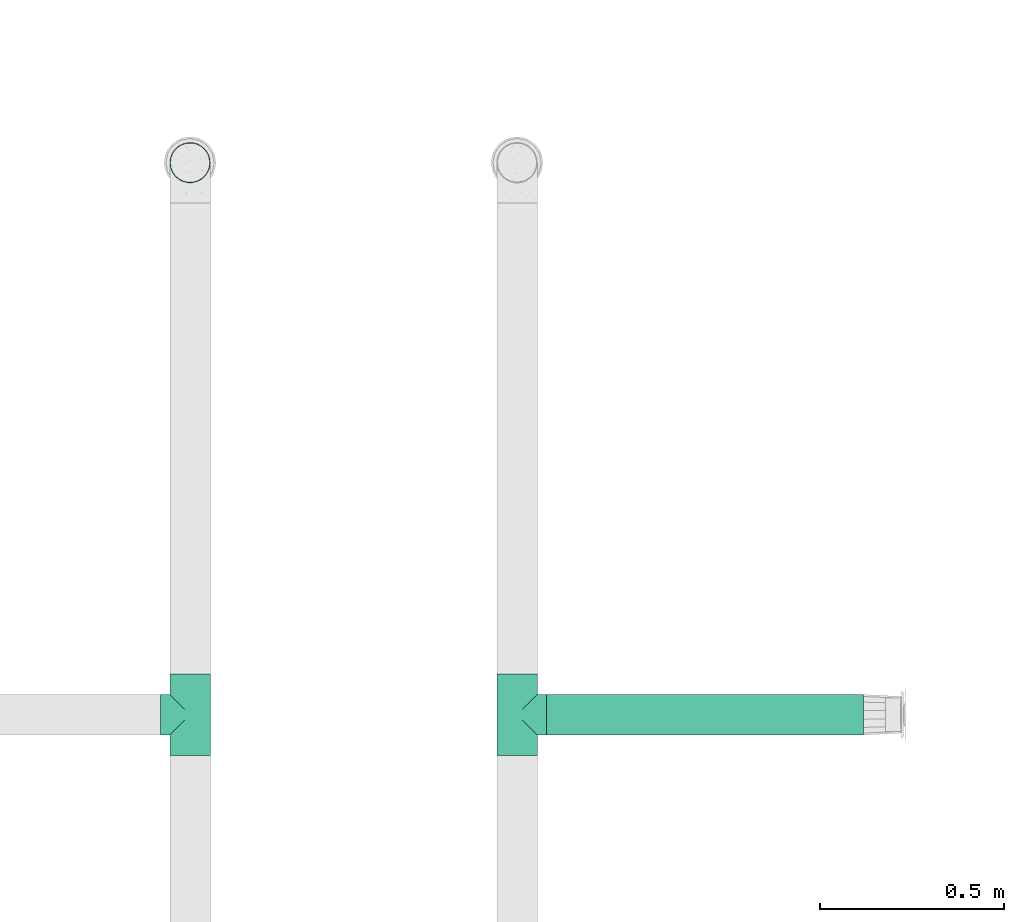
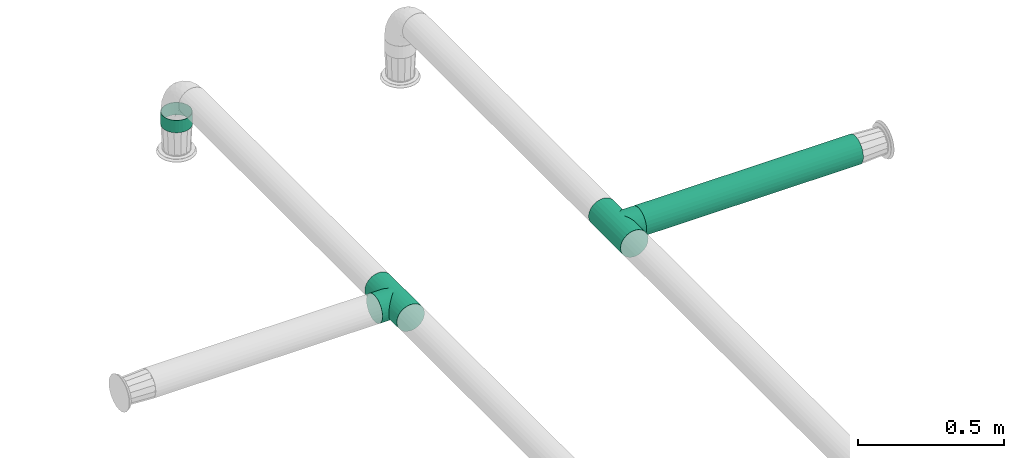
# One storey, part 28 of 123: 2 flow fittings, 2 flow segments.
"""IFC2X3 building model written with IfcOpenShell, lengths in millimetres."""

from ifc_helpers import new_model, entity, si_unit, converted_unit, derived_unit, direction, frame, origin_with_axes, origin_2d_with_axis, place, context, subcontext, project, spatial, hollow_circle, extrude, open_shell, surface_model, source, transform, mapped, material, layer, layer_set, layer_usage, type_object, element, save


model = new_model("IFC2X3")

# Units and contexts
model_context = context("Model", 3, precision=1e-05, world=origin_with_axes(), true_north=direction((0.0, 1.0)))
body_context = subcontext(model_context, "Body", "Model", "MODEL_VIEW")
ifc_project = project(units=[si_unit("AREAUNIT", "SQUARE_METRE"), si_unit("VOLUMEUNIT", "CUBIC_METRE", prefix="DECI"), si_unit("TIMEUNIT", "SECOND"), si_unit("THERMODYNAMICTEMPERATUREUNIT", "DEGREE_CELSIUS"), si_unit("PRESSUREUNIT", "PASCAL"), si_unit("MASSUNIT", "GRAM", prefix="KILO"), si_unit("LENGTHUNIT", "METRE", prefix="MILLI"), si_unit("POWERUNIT", "WATT"), si_unit("ELECTRICCURRENTUNIT", "AMPERE"), si_unit("ELECTRICVOLTAGEUNIT", "VOLT"), derived_unit("VOLUMETRICFLOWRATEUNIT", [(si_unit("VOLUMEUNIT", "CUBIC_METRE", prefix="DECI"), 1), (si_unit("TIMEUNIT", "SECOND"), -1)]), derived_unit("LINEARVELOCITYUNIT", [(si_unit("LENGTHUNIT", "METRE"), 1), (si_unit("TIMEUNIT", "SECOND"), -1)]), derived_unit("MASSDENSITYUNIT", [(si_unit("MASSUNIT", "GRAM", prefix="KILO"), 1), (si_unit("VOLUMEUNIT", "CUBIC_METRE"), -1)]), converted_unit("PLANEANGLEUNIT", "DEGREE", entity("IfcRatioMeasure", 0.01745), si_unit("PLANEANGLEUNIT", "RADIAN"), dimensions=[0, 0, 0, 0, 0, 0, 0])], contexts=[model_context])

# Site, building, storey
site_placement = place(None, origin_with_axes())
site = spatial("IfcSite", under=ifc_project, at=site_placement, CompositionType="ELEMENT")
building_placement = place(site_placement, origin_with_axes())
building = spatial("IfcBuilding", under=site, at=building_placement, Name="mc-building", CompositionType="ELEMENT")
storey_placement = place(building_placement, origin_with_axes())
storey = spatial("IfcBuildingStorey", under=building, at=storey_placement, Name="1. Korrus", CompositionType="ELEMENT", Elevation=0.0)

# Flow fitting
duct_fitting_type = type_object("IfcDuctFittingType", PredefinedType="JUNCTION")
shared_shape_1 = source(origin_with_axes(), body_context, "Body", "SurfaceModel", [
    surface_model("IfcShellBasedSurfaceModel", [(0.0, -80.0, -55.0), (14.23505, -80.0, -53.12592), (-14.23505, -80.0, -53.12592), (-53.12592, -80.0, 14.23505), (-27.5, -80.0, -47.63139), (-47.63139, -80.0, -27.5), (-38.89087, -80.0, -38.89087), (55.0, -80.0, 0.0), (53.12592, -80.0, 14.23505), (38.89087, -80.0, -38.89087), (27.5, -80.0, -47.63139), (53.12592, -80.0, -14.23505), (47.63139, -80.0, -27.5), (-53.12592, -80.0, -14.23505), (-47.63139, -80.0, 27.5), (-38.89087, -80.0, 38.89087), (14.23505, -80.0, 53.12592), (-27.5, -80.0, 47.63139), (-14.23505, -80.0, 53.12592), (47.63139, -80.0, 27.5), (38.89087, -80.0, 38.89087), (27.5, -80.0, 47.63139), (0.0, -80.0, 55.0), (-55.0, -80.0, 0.0), (0.0, 0.0, 55.0), (-7.4066, -7.4066, 54.49901), (-14.74521, -14.74521, 52.98659), (-21.93978, -21.93978, 50.43457), (-28.89905, -28.89905, 46.79578), (-35.50357, -35.50357, 42.00591), (-41.58668, -41.58668, 35.99373), (-46.92319, -46.92319, 28.69171), (-51.19777, -51.19777, 20.0945), (-50.37866, -80.0, 20.86752), (-54.01174, -54.01174, 10.37938), (-55.0, -55.0, 0.0), (-54.06296, -80.0, 7.11752), (-54.01174, -54.01174, -10.37938), (-51.19777, -51.19777, -20.0945), (-54.06296, -80.0, -7.11752), (-46.92319, -46.92319, -28.69171), (-41.58668, -41.58668, -35.99373), (-50.37866, -80.0, -20.86752), (-35.50357, -35.50357, -42.00591), (-21.93978, -21.93978, -50.43457), (-14.74521, -14.74521, -52.98659), (-7.4066, -7.4066, -54.49901), (0.0, 0.0, -55.0), (-28.89905, -28.89905, -46.79578), (7.4066, -7.4066, -54.49901), (14.74521, -14.74521, -52.98659), (21.93978, -21.93978, -50.43457), (28.89905, -28.89905, -46.79578), (35.50357, -35.50357, -42.00591), (41.58668, -41.58668, -35.99373), (46.92319, -46.92319, -28.69171), (51.19777, -51.19777, -20.0945), (50.37866, -80.0, -20.86752), (54.01174, -54.01174, -10.37938), (55.0, -55.0, 0.0), (54.06296, -80.0, -7.11752), (54.01174, -54.01174, 10.37938), (51.19777, -51.19777, 20.0945), (54.06296, -80.0, 7.11752), (46.92319, -46.92319, 28.69171), (41.58668, -41.58668, 35.99373), (50.37866, -80.0, 20.86752), (35.50357, -35.50357, 42.00591), (21.93978, -21.93978, 50.43457), (14.74521, -14.74521, 52.98659), (7.4066, -7.4066, 54.49901), (28.89905, -28.89905, 46.79578), (-110.0, 0.0, -55.0), (-110.0, -14.23505, -53.12592), (-110.0, 14.23505, -53.12592), (-110.0, 53.12592, 14.23505), (-110.0, 27.5, -47.63139), (-110.0, 47.63139, -27.5), (-110.0, 38.89087, -38.89087), (-110.0, -55.0, 0.0), (-110.0, -53.12592, 14.23505), (-110.0, -38.89087, -38.89087), (-110.0, -27.5, -47.63139), (-110.0, -53.12592, -14.23505), (-110.0, -47.63139, -27.5), (-110.0, 53.12592, -14.23505), (-110.0, 47.63139, 27.5), (-110.0, 38.89087, 38.89087), (-110.0, -14.23505, 53.12592), (-110.0, 27.5, 47.63139), (-110.0, 14.23505, 53.12592), (-110.0, -47.63139, 27.5), (-110.0, -38.89087, 38.89087), (-110.0, -27.5, 47.63139), (-110.0, 0.0, 55.0), (-110.0, 55.0, 0.0), (110.0, 55.0, 0.0), (110.0, 0.0, -55.0), (110.0, 14.23505, -53.12592), (110.0, 27.5, -47.63139), (110.0, 38.89087, -38.89087), (110.0, 47.63139, -27.5), (110.0, -38.89087, -38.89087), (110.0, -53.12592, 14.23505), (110.0, -27.5, -47.63139), (110.0, -14.23505, -53.12592), (110.0, -47.63139, -27.5), (110.0, -53.12592, -14.23505), (110.0, -55.0, 0.0), (110.0, 53.12592, -14.23505), (110.0, 53.12592, 14.23505), (110.0, 47.63139, 27.5), (110.0, 38.89087, 38.89087), (110.0, 0.0, 55.0), (110.0, 27.5, 47.63139), (110.0, 14.23505, 53.12592), (110.0, -47.63139, 27.5), (110.0, -38.89087, 38.89087), (110.0, -27.5, 47.63139), (110.0, -14.23505, 53.12592)], [open_shell([[[0, 1, 2]], [[2, 3, 4]], [[5, 6, 3]], [[6, 4, 3]], [[2, 7, 8]], [[9, 7, 10]], [[1, 10, 7]], [[11, 7, 12]], [[9, 12, 7]], [[7, 2, 1]], [[5, 3, 13]], [[2, 14, 3]], [[2, 15, 14]], [[2, 16, 17]], [[17, 15, 2]], [[16, 18, 17]], [[2, 8, 19]], [[2, 19, 20]], [[2, 20, 21]], [[16, 2, 21]], [[16, 22, 18]], [[23, 13, 3]], [[24, 25, 22]], [[26, 27, 18]], [[25, 26, 18]], [[22, 25, 18]], [[17, 28, 29]], [[17, 18, 27]], [[17, 29, 15]], [[28, 17, 27]], [[30, 31, 14]], [[32, 3, 33]], [[32, 34, 3]], [[35, 36, 34]], [[31, 32, 14]], [[15, 30, 14]], [[34, 36, 3]], [[33, 14, 32]], [[36, 35, 23]], [[30, 15, 29]], [[37, 38, 13]], [[37, 13, 39]], [[40, 41, 5]], [[38, 5, 42]], [[38, 40, 5]], [[37, 39, 35]], [[35, 39, 23]], [[13, 38, 42]], [[41, 6, 5]], [[41, 43, 6]], [[44, 45, 2]], [[46, 47, 0]], [[45, 46, 2]], [[43, 48, 4]], [[44, 4, 48]], [[44, 2, 4]], [[46, 0, 2]], [[43, 4, 6]], [[47, 49, 0]], [[50, 51, 1]], [[49, 50, 1]], [[0, 49, 1]], [[10, 52, 53]], [[10, 1, 51]], [[10, 53, 9]], [[52, 10, 51]], [[54, 55, 12]], [[56, 11, 57]], [[56, 58, 11]], [[59, 60, 58]], [[55, 56, 12]], [[9, 54, 12]], [[58, 60, 11]], [[57, 12, 56]], [[60, 59, 7]], [[54, 9, 53]], [[61, 62, 8]], [[61, 8, 63]], [[64, 65, 19]], [[62, 19, 66]], [[62, 64, 19]], [[61, 63, 59]], [[7, 59, 63]], [[62, 66, 8]], [[65, 20, 19]], [[65, 67, 20]], [[68, 69, 16]], [[70, 24, 22]], [[69, 70, 16]], [[67, 71, 21]], [[68, 21, 71]], [[68, 16, 21]], [[70, 22, 16]], [[67, 21, 20]], [[72, 73, 74]], [[74, 75, 76]], [[77, 78, 75]], [[76, 75, 78]], [[74, 79, 80]], [[81, 79, 82]], [[73, 82, 79]], [[83, 79, 84]], [[81, 84, 79]], [[79, 74, 73]], [[77, 75, 85]], [[74, 86, 75]], [[74, 87, 86]], [[74, 88, 89]], [[89, 87, 74]], [[88, 90, 89]], [[74, 91, 92]], [[91, 74, 80]], [[92, 93, 74]], [[74, 93, 88]], [[88, 94, 90]], [[95, 85, 75]], [[96, 97, 98]], [[99, 96, 98]], [[96, 100, 101]], [[100, 96, 99]], [[102, 97, 103]], [[97, 102, 104]], [[104, 105, 97]], [[102, 103, 106]], [[106, 103, 107]], [[108, 107, 103]], [[109, 96, 101]], [[110, 111, 97]], [[97, 111, 112]], [[113, 97, 114]], [[97, 112, 114]], [[113, 114, 115]], [[116, 103, 97]], [[117, 116, 97]], [[118, 117, 97]], [[119, 118, 97]], [[119, 97, 113]], [[96, 110, 97]], [[24, 113, 115]], [[89, 115, 114]], [[94, 24, 90]], [[90, 24, 115]], [[115, 89, 90]], [[114, 87, 89]], [[86, 112, 111]], [[75, 111, 110]], [[95, 110, 96]], [[87, 112, 86]], [[86, 111, 75]], [[110, 95, 75]], [[112, 87, 114]], [[85, 96, 109]], [[77, 109, 101]], [[95, 96, 85]], [[85, 109, 77]], [[101, 78, 77]], [[101, 100, 78]], [[76, 100, 99]], [[74, 99, 98]], [[47, 98, 97]], [[76, 99, 74]], [[47, 72, 74]], [[98, 47, 74]], [[100, 76, 78]], [[47, 46, 72]], [[45, 44, 73]], [[46, 45, 73]], [[72, 46, 73]], [[82, 48, 43]], [[82, 73, 44]], [[82, 43, 81]], [[48, 82, 44]], [[41, 40, 84]], [[38, 37, 83]], [[40, 38, 84]], [[81, 41, 84]], [[37, 79, 83]], [[83, 84, 38]], [[79, 37, 35]], [[41, 81, 43]], [[49, 97, 105]], [[105, 104, 51]], [[53, 104, 102]], [[53, 52, 104]], [[49, 47, 97]], [[51, 50, 105]], [[52, 51, 104]], [[49, 105, 50]], [[54, 102, 106]], [[56, 106, 107]], [[58, 107, 108]], [[55, 54, 106]], [[58, 56, 107]], [[59, 58, 108]], [[55, 106, 56]], [[102, 54, 53]], [[34, 32, 80]], [[31, 30, 91]], [[32, 31, 91]], [[35, 34, 79]], [[80, 79, 34]], [[32, 91, 80]], [[30, 92, 91]], [[30, 29, 92]], [[27, 26, 88]], [[25, 24, 94]], [[26, 25, 88]], [[29, 28, 93]], [[27, 93, 28]], [[27, 88, 93]], [[25, 94, 88]], [[29, 93, 92]], [[61, 108, 103]], [[62, 103, 116]], [[65, 116, 117]], [[61, 59, 108]], [[64, 62, 116]], [[65, 64, 116]], [[61, 103, 62]], [[117, 67, 65]], [[71, 67, 118]], [[118, 67, 117]], [[68, 118, 119]], [[70, 119, 113]], [[68, 71, 118]], [[70, 69, 119]], [[24, 70, 113]], [[68, 119, 69]]])]),
])
flow_fitting_1_placement = place(storey_placement, frame((9245.0, 3217.8145, 2465.0), z_axis=(0.0, 0.0, 1.0), x_axis=(0.0, 1.0, 0.0)))
element("IfcFlowFitting", 1, at=flow_fitting_1_placement, inside=storey, type_object=duct_fitting_type, context=body_context, shape_type="MappedRepresentation", body=[
    mapped(shared_shape_1, transform((0.0, 0.0, 0.0), scale=1.0)),
])

# Flow segments
ifc_material = material(Name="FZ1")
ifc_layer = layer(ifc_material, 0.0)
ifc_layer_set = layer_set([ifc_layer], Name="FZ1")
ifc_layer_usage = layer_usage(ifc_layer_set, "AXIS1", "POSITIVE", 0.0)
duct_segment_type = type_object("IfcDuctSegmentType", PredefinedType="RIGIDSEGMENT")
shared_shape_2 = source(origin_with_axes(), body_context, "Body", "SweptSolid", [
    extrude(hollow_circle(Radius=55.0, WallThickness=2.0, at=origin_2d_with_axis()), frame((0.0, 0.0, 0.0), z_axis=(1.0, 0.0, 0.0), x_axis=(0.0, 1.0, 0.0)), (0.0, 0.0, 1.0), 51.9),
])
flow_segment_1_placement = place(storey_placement, frame((8357.82156, 4715.81442, 2355.0), z_axis=(0.0, 1.0, 0.0), x_axis=(0.0, 0.0, -1.0)))
element("IfcFlowSegment", 2, at=flow_segment_1_placement, inside=storey, type_object=duct_segment_type, material=ifc_layer_usage, context=body_context, shape_type="MappedRepresentation", body=[
    mapped(shared_shape_2, transform((0.0, 0.0, 0.0), scale=1.0)),
])
shared_shape_3 = source(origin_with_axes(), body_context, "Body", "SweptSolid", [
    extrude(hollow_circle(Radius=55.0, WallThickness=2.0, at=origin_2d_with_axis()), frame((0.0, 0.0, 0.0), z_axis=(1.0, 0.0, 0.0), x_axis=(0.0, 1.0, 0.0)), (0.0, 0.0, 1.0), 859.9),
])
flow_segment_2_placement = place(storey_placement, frame((9325.0, 3217.8145, 2465.0), z_axis=(0.0, 0.0, 1.0), x_axis=(1.0, 0.0, 0.0)))
element("IfcFlowSegment", 3, at=flow_segment_2_placement, inside=storey, type_object=duct_segment_type, material=ifc_layer_usage, context=body_context, shape_type="MappedRepresentation", body=[
    mapped(shared_shape_3, transform((0.0, 0.0, 0.0), scale=1.0)),
])

# Flow fitting
shared_shape_4 = source(origin_with_axes(), body_context, "Body", "SurfaceModel", [
    surface_model("IfcShellBasedSurfaceModel", [(-110.0, -38.89087, -38.89087), (-110.0, -55.0, 0.0), (-110.0, -27.5, -47.63139), (-110.0, -53.12592, -14.23505), (-110.0, -47.63139, -27.5), (-110.0, 47.63139, -27.5), (-110.0, 53.12592, 14.23505), (-110.0, 53.12592, -14.23505), (-110.0, 55.0, 0.0), (110.0, 38.89087, -38.89087), (110.0, 55.0, 0.0), (110.0, 27.5, -47.63139), (110.0, -38.89087, -38.89087), (110.0, -53.12592, 14.23505), (110.0, -47.63139, -27.5), (110.0, -55.0, 0.0), (110.0, -53.12592, -14.23505), (110.0, 53.12592, -14.23505), (110.0, 47.63139, -27.5), (-110.0, 38.89087, -38.89087), (-110.0, -14.23505, -53.12592), (-110.0, 0.0, -55.0), (-110.0, 27.5, -47.63139), (-110.0, 14.23505, -53.12592), (-110.0, -53.12592, 14.23505), (-110.0, -47.63139, 27.5), (-110.0, -38.89087, 38.89087), (-110.0, 14.23505, 53.12592), (-110.0, 27.5, 47.63139), (-55.0, 80.0, 0.0), (0.0, 80.0, -55.0), (-14.23505, 80.0, -53.12592), (-27.5, 80.0, -47.63139), (-38.89087, 80.0, -38.89087), (-47.63139, 80.0, -27.5), (38.89087, 80.0, -38.89087), (53.12592, 80.0, 14.23505), (27.5, 80.0, -47.63139), (14.23505, 80.0, -53.12592), (47.63139, 80.0, -27.5), (53.12592, 80.0, -14.23505), (55.0, 80.0, 0.0), (-53.12592, 80.0, -14.23505), (-53.12592, 80.0, 14.23505), (-47.63139, 80.0, 27.5), (-38.89087, 80.0, 38.89087), (0.0, 80.0, 55.0), (-27.5, 80.0, 47.63139), (-14.23505, 80.0, 53.12592), (47.63139, 80.0, 27.5), (38.89087, 80.0, 38.89087), (27.5, 80.0, 47.63139), (14.23505, 80.0, 53.12592), (-7.4066, 7.4066, 54.49901), (0.0, 0.0, 55.0), (-21.93978, 21.93978, 50.43457), (-14.74521, 14.74521, 52.98659), (-35.50357, 35.50357, 42.00591), (-28.89905, 28.89905, 46.79578), (-46.92319, 46.92319, 28.69171), (-41.58668, 41.58668, 35.99373), (-54.01174, 54.01174, 10.37938), (-54.06296, 80.0, 7.11752), (-55.0, 55.0, 0.0), (-51.19777, 51.19777, 20.0945), (-50.37866, 80.0, 20.86752), (-51.19777, 51.19777, -20.0945), (-54.01174, 54.01174, -10.37938), (-50.37866, 80.0, -20.86752), (-41.58668, 41.58668, -35.99373), (-46.92319, 46.92319, -28.69171), (-54.06296, 80.0, -7.11752), (-35.50357, 35.50357, -42.00591), (-14.74521, 14.74521, -52.98659), (-21.93978, 21.93978, -50.43457), (0.0, 0.0, -55.0), (-7.4066, 7.4066, -54.49901), (-28.89905, 28.89905, -46.79578), (7.4066, 7.4066, -54.49901), (21.93978, 21.93978, -50.43457), (14.74521, 14.74521, -52.98659), (35.50357, 35.50357, -42.00591), (28.89905, 28.89905, -46.79578), (46.92319, 46.92319, -28.69171), (41.58668, 41.58668, -35.99373), (54.01174, 54.01174, -10.37938), (54.06296, 80.0, -7.11752), (55.0, 55.0, 0.0), (51.19777, 51.19777, -20.0945), (50.37866, 80.0, -20.86752), (51.19777, 51.19777, 20.0945), (54.01174, 54.01174, 10.37938), (50.37866, 80.0, 20.86752), (41.58668, 41.58668, 35.99373), (46.92319, 46.92319, 28.69171), (54.06296, 80.0, 7.11752), (35.50357, 35.50357, 42.00591), (14.74521, 14.74521, 52.98659), (21.93978, 21.93978, 50.43457), (7.4066, 7.4066, 54.49901), (28.89905, 28.89905, 46.79578), (-110.0, -27.5, 47.63139), (-110.0, 0.0, 55.0), (-110.0, -14.23505, 53.12592), (-110.0, 47.63139, 27.5), (-110.0, 38.89087, 38.89087), (110.0, 0.0, -55.0), (110.0, 14.23505, -53.12592), (110.0, -14.23505, -53.12592), (110.0, -27.5, -47.63139), (110.0, 53.12592, 14.23505), (110.0, -47.63139, 27.5), (110.0, -38.89087, 38.89087), (110.0, 14.23505, 53.12592), (110.0, -27.5, 47.63139), (110.0, -14.23505, 53.12592), (110.0, 47.63139, 27.5), (110.0, 38.89087, 38.89087), (110.0, 27.5, 47.63139), (110.0, 0.0, 55.0)], [open_shell([[[0, 1, 2]], [[3, 1, 4]], [[5, 6, 7]], [[8, 7, 6]], [[9, 10, 11]], [[12, 13, 14]], [[15, 16, 13]], [[17, 10, 18]], [[19, 6, 5]], [[2, 1, 20]], [[19, 21, 6]], [[21, 19, 22]], [[22, 23, 21]], [[24, 25, 21]], [[21, 25, 26]], [[27, 28, 21]], [[29, 30, 31]], [[32, 29, 31]], [[29, 33, 34]], [[29, 32, 33]], [[35, 30, 36]], [[30, 35, 37]], [[37, 38, 30]], [[35, 36, 39]], [[39, 36, 40]], [[41, 40, 36]], [[42, 29, 34]], [[43, 44, 30]], [[30, 44, 45]], [[46, 30, 47]], [[30, 45, 47]], [[46, 47, 48]], [[49, 36, 30]], [[50, 49, 30]], [[51, 50, 30]], [[52, 51, 30]], [[52, 30, 46]], [[29, 43, 30]], [[46, 53, 54]], [[48, 55, 56]], [[48, 56, 53]], [[48, 53, 46]], [[57, 58, 47]], [[55, 48, 47]], [[45, 57, 47]], [[55, 47, 58]], [[44, 59, 60]], [[61, 62, 63]], [[43, 61, 64]], [[65, 43, 64]], [[44, 64, 59]], [[44, 60, 45]], [[43, 62, 61]], [[64, 44, 65]], [[29, 63, 62]], [[57, 45, 60]], [[42, 66, 67]], [[68, 34, 66]], [[34, 69, 70]], [[71, 42, 67]], [[34, 70, 66]], [[63, 71, 67]], [[29, 71, 63]], [[68, 66, 42]], [[34, 33, 69]], [[33, 72, 69]], [[31, 73, 74]], [[30, 75, 76]], [[31, 76, 73]], [[32, 77, 72]], [[77, 32, 74]], [[32, 31, 74]], [[31, 30, 76]], [[33, 32, 72]], [[30, 78, 75]], [[38, 79, 80]], [[38, 80, 78]], [[38, 78, 30]], [[81, 82, 37]], [[79, 38, 37]], [[35, 81, 37]], [[79, 37, 82]], [[39, 83, 84]], [[85, 86, 87]], [[40, 85, 88]], [[89, 40, 88]], [[39, 88, 83]], [[39, 84, 35]], [[40, 86, 85]], [[88, 39, 89]], [[41, 87, 86]], [[81, 35, 84]], [[36, 90, 91]], [[92, 49, 90]], [[49, 93, 94]], [[95, 36, 91]], [[49, 94, 90]], [[87, 95, 91]], [[95, 87, 41]], [[36, 92, 90]], [[49, 50, 93]], [[50, 96, 93]], [[52, 97, 98]], [[46, 54, 99]], [[52, 99, 97]], [[51, 100, 96]], [[100, 51, 98]], [[51, 52, 98]], [[52, 46, 99]], [[50, 51, 96]], [[1, 21, 20]], [[1, 0, 4]], [[101, 102, 26]], [[102, 21, 26]], [[102, 101, 103]], [[104, 6, 21]], [[105, 104, 21]], [[105, 21, 28]], [[21, 102, 27]], [[1, 24, 21]], [[106, 107, 108]], [[108, 13, 109]], [[109, 13, 12]], [[108, 10, 110]], [[107, 11, 10]], [[9, 18, 10]], [[10, 108, 107]], [[16, 14, 13]], [[108, 111, 13]], [[108, 112, 111]], [[108, 113, 114]], [[114, 112, 108]], [[113, 115, 114]], [[108, 110, 116]], [[108, 116, 117]], [[108, 117, 118]], [[113, 108, 118]], [[113, 119, 115]], [[115, 119, 54]], [[114, 115, 101]], [[103, 54, 102]], [[115, 54, 103]], [[103, 101, 115]], [[101, 26, 114]], [[111, 112, 25]], [[13, 111, 24]], [[15, 13, 1]], [[25, 112, 26]], [[24, 111, 25]], [[24, 1, 13]], [[114, 26, 112]], [[16, 15, 3]], [[14, 16, 4]], [[3, 15, 1]], [[4, 16, 3]], [[4, 0, 14]], [[0, 12, 14]], [[109, 12, 2]], [[108, 109, 20]], [[106, 108, 75]], [[20, 109, 2]], [[20, 21, 75]], [[20, 75, 108]], [[0, 2, 12]], [[21, 76, 75]], [[23, 74, 73]], [[23, 73, 76]], [[23, 76, 21]], [[72, 77, 22]], [[74, 23, 22]], [[19, 72, 22]], [[74, 22, 77]], [[5, 70, 69]], [[7, 67, 66]], [[5, 66, 70]], [[5, 69, 19]], [[7, 8, 67]], [[66, 5, 7]], [[63, 67, 8]], [[72, 19, 69]], [[107, 106, 78]], [[79, 11, 107]], [[9, 11, 81]], [[11, 82, 81]], [[106, 75, 78]], [[107, 80, 79]], [[11, 79, 82]], [[80, 107, 78]], [[18, 9, 84]], [[17, 18, 88]], [[10, 17, 85]], [[18, 84, 83]], [[17, 88, 85]], [[10, 85, 87]], [[88, 18, 83]], [[81, 84, 9]], [[110, 10, 91]], [[116, 110, 90]], [[117, 116, 93]], [[10, 87, 91]], [[116, 90, 94]], [[116, 94, 93]], [[90, 110, 91]], [[93, 96, 117]], [[118, 96, 100]], [[117, 96, 118]], [[113, 118, 98]], [[119, 113, 99]], [[118, 100, 98]], [[113, 97, 99]], [[119, 99, 54]], [[97, 113, 98]], [[6, 64, 61]], [[104, 60, 59]], [[104, 59, 64]], [[8, 61, 63]], [[61, 8, 6]], [[6, 104, 64]], [[104, 105, 60]], [[105, 57, 60]], [[27, 56, 55]], [[102, 54, 53]], [[27, 53, 56]], [[28, 58, 57]], [[58, 28, 55]], [[28, 27, 55]], [[27, 102, 53]], [[105, 28, 57]]])]),
])
flow_fitting_2_placement = place(storey_placement, frame((8357.82156, 3217.8145, 2465.0), z_axis=(0.0, 0.0, 1.0), x_axis=(0.0, 1.0, 0.0)))
element("IfcFlowFitting", 4, at=flow_fitting_2_placement, inside=storey, type_object=duct_fitting_type, context=body_context, shape_type="MappedRepresentation", body=[
    mapped(shared_shape_4, transform((0.0, 0.0, 0.0), scale=1.0)),
])

save(model, "model.ifc")
